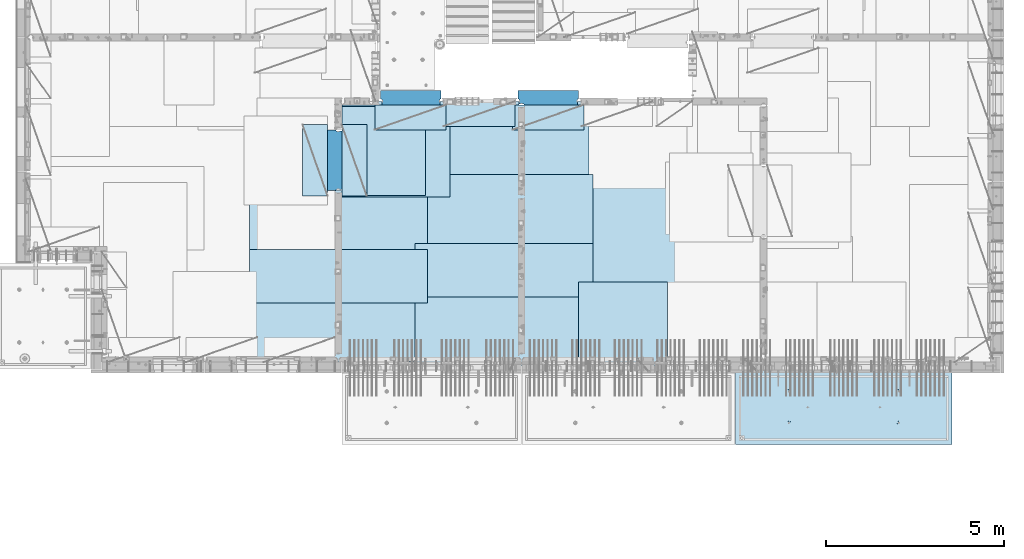
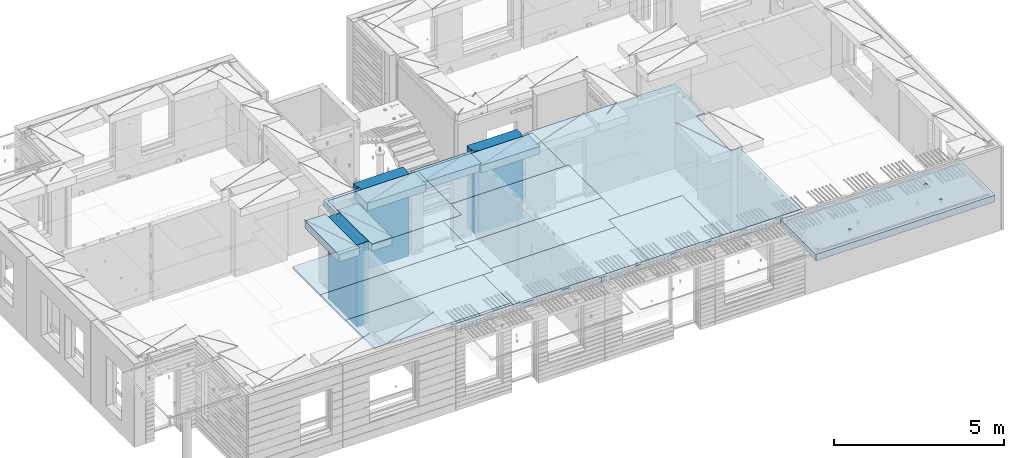
# One storey, part 196 of 334: 18 plates, 3 slabs, 19 elements without a shape of their own.
"""IFC2X3 building model written with IfcOpenShell, lengths in millimetres."""

from ifc_helpers import new_model, si_unit, frame, origin_with_axes, place, context, subcontext, project, spatial, faceted_brep, material, type_object, element, aggregate, save


model = new_model("IFC2X3")

# Units and contexts
model_context = context("Model", 3, precision=1e-05, world=origin_with_axes())
body_context = subcontext(model_context, "Body", "Model", "MODEL_VIEW")
ifc_project = project(units=[si_unit("LENGTHUNIT", "METRE", prefix="MILLI"), si_unit("AREAUNIT", "SQUARE_METRE"), si_unit("VOLUMEUNIT", "CUBIC_METRE"), si_unit("MASSUNIT", "GRAM", prefix="KILO"), si_unit("TIMEUNIT", "SECOND"), si_unit("PLANEANGLEUNIT", "RADIAN"), si_unit("SOLIDANGLEUNIT", "STERADIAN"), si_unit("THERMODYNAMICTEMPERATUREUNIT", "DEGREE_CELSIUS"), si_unit("LUMINOUSINTENSITYUNIT", "LUMEN")], contexts=[model_context])

# Site, building, storey
site_placement = place(None, origin_with_axes())
site = spatial("IfcSite", under=ifc_project, at=site_placement, CompositionType="ELEMENT")
building_placement = place(site_placement, origin_with_axes())
building = spatial("IfcBuilding", under=site, at=building_placement, CompositionType="ELEMENT")
storey_placement = place(building_placement, origin_with_axes())
storey = spatial("IfcBuildingStorey", under=building, at=storey_placement, Name="3", CompositionType="ELEMENT", Elevation=0.0)

# Assembly, slab
assembly_1_placement = place(storey_placement, origin_with_axes())
assembly_1 = element("IfcElementAssembly", 1, at=assembly_1_placement, inside=storey, AssemblyPlace="NOTDEFINED", PredefinedType="REINFORCEMENT_UNIT")
ifc_material_1 = material(Name="CONCRETE/C30/37")
slab_type_1 = type_object("IfcSlabType", PredefinedType="NOTDEFINED")
slab_1_placement = place(assembly_1_placement, frame((21810.0, 7750.0, 90595.0), z_axis=(0.0, 1.0, 0.0), x_axis=(1.0, 0.0, 0.0)))
slab_1 = element("IfcSlab", 2, at=slab_1_placement, type_object=slab_type_1, material=ifc_material_1, PredefinedType="FLOOR", context=body_context, shape_type="Brep", body=[
    faceted_brep([(6500.0, -135.0, 3780.0), (6500.0, -135.0, 3637.99963378906), (6500.0, 135.0, 3637.99963378906), (6500.0, 135.0, 3780.0), (6800.0, -135.0, 3637.99963378906), (6800.0, 135.0, 3637.99963378906), (6800.0, 135.0, 7430.0), (6800.0, -135.0, 7430.0), (6800.0, -135.0, 5680.0), (6800.0, 135.0, 5680.0), (1569.99914550782, 135.0, 7430.0), (1569.99914550782, -135.0, 7430.0), (1569.99914550782, 135.0, 7330.0), (1569.99914550782, -135.0, 7330.0), (0.0, 135.0, 7330.0), (0.0, -135.0, 7330.0), (1.81898940354586e-12, -135.0, 1.81898940354586e-12), (1.81898940354586e-12, 135.0, 1.81898940354586e-12), (6800.0, -135.0, 0.0), (6800.0, 135.0, 0.0), (6500.0, -135.0, 5637.99963378906), (6500.0, -135.0, 5680.0), (6500.0, 135.0, 5680.0), (6500.0, 135.0, 5637.99963378906)], [[[0, 1, 2, 3]], [[4, 5, 2, 1]], [[6, 7, 8, 9]], [[7, 6, 10, 11]], [[11, 10, 12, 13]], [[13, 12, 14, 15]], [[16, 15, 14, 17]], [[18, 16, 17, 19]], [[7, 11, 13, 15, 16, 18, 4, 1, 0, 20, 21, 8]], [[8, 21, 22, 9]], [[20, 0, 3, 23, 22, 21]], [[23, 3, 2, 5, 19, 17, 14, 12, 10, 6, 9, 22]], [[18, 19, 5, 4]]]),
])

assembly_2_placement = place(storey_placement, origin_with_axes())
assembly_2 = element("IfcElementAssembly", 3, at=assembly_2_placement, inside=storey, AssemblyPlace="NOTDEFINED", PredefinedType="REINFORCEMENT_UNIT")
ifc_material_2 = material(Name="CONCRETE/C35/45")
slab_type_2 = type_object("IfcSlabType", PredefinedType="NOTDEFINED")
slab_2_placement = place(assembly_2_placement, frame((33909.9998568133, 7629.99655735226, 90590.0), z_axis=(-1.11800000013248e-06, -0.999999999999375, 0.0), x_axis=(-0.999999999999093, 1.34699999998405e-06, 0.0)))
slab_2 = element("IfcSlab", 4, at=slab_2_placement, type_object=slab_type_2, material=ifc_material_2, PredefinedType="FLOOR", context=body_context, shape_type="Brep", body=[
    faceted_brep([(4605.44993885855, -113.0, 552.448239707288), (4619.38834372919, -113.0, 559.550231553701), (4630.44991833371, -113.0, 570.61183115741), (4637.55187867931, -113.0, 584.55025207851), (4639.99903540509, -113.0, 600.001104562554), (4637.55184376039, -113.0, 615.451951515985), (4630.44985191398, -113.0, 629.39035638662), (4619.38825231027, -113.0, 640.451930991143), (4605.44983138917, -113.0, 647.553891336743), (4589.99897890513, -113.0, 650.001048062522), (4574.54813195169, -113.0, 647.553856417822), (4560.60972708106, -113.0, 640.451864571409), (4549.54815247653, -113.0, 629.390264967699), (4542.44619213093, -113.0, 615.451844046599), (4539.99903540516, -113.0, 600.000991562554), (4542.44622704986, -113.0, 584.550144609124), (4549.54821889627, -113.0, 570.61173973849), (4560.60981849998, -113.0, 559.550165133966), (4574.54823942108, -113.0, 552.448204788368), (4589.99909190512, -113.0, 550.001048062586), (4548.90468317908, -120.0, 570.144182560607), (4541.68970509875, -120.0, 584.304334781456), (4560.14226277649, -120.0, 558.906628360102), (4574.30243130315, -120.0, 551.691682281732), (4589.99909280399, -120.0, 549.205593517132), (4605.69574868622, -120.0, 551.691717756181), (4619.85590090707, -120.0, 558.906695836513), (4631.09345510757, -120.0, 570.14427543392), (4638.30840118594, -120.0, 584.304443960583), (4640.79448995055, -120.0, 600.001105461418), (4638.30836571149, -120.0, 615.697761343653), (4631.09338763116, -120.0, 629.857913564502), (4619.85580803376, -120.0, 641.095467765007), (4605.6956395071, -120.0, 648.310413843377), (4589.99897800626, -120.0, 650.796502607977), (4574.30232212402, -120.0, 648.310378368928), (4560.14216990317, -120.0, 641.095400288596), (4548.90461570267, -120.0, 629.85782069119), (4541.6896696243, -120.0, 615.697652164527), (4539.2035808597, -120.0, 600.000990663691), (0.000819232023786753, -120.0, 2085.00366210938), (6090.0009765625, -120.0, 2085.00366210938), (6090.0009765625, 120.0, 2085.00366210938), (0.000819232023786753, 120.0, 2085.00366210938), (6090.0, -120.0, 1.39971234602854e-09), (6090.0, 120.0, 1.39971234602854e-09), (-7.27595761418343e-12, -120.0, -9.09494701772928e-13), (-7.27595761418343e-12, 120.0, -9.09494701772928e-13), (1515.44893888152, -108.0, 1437.45474794476), (1529.38734375216, -108.0, 1444.55673979117), (1540.44891835668, -108.0, 1455.61833939488), (1547.55087870228, -108.0, 1469.55676031598), (1549.99803542806, -108.0, 1485.00761280002), (1547.55084378336, -108.0, 1500.45845975345), (1540.44885193695, -108.0, 1514.39686462409), (1529.38725233324, -108.0, 1525.45843922861), (1515.44883141214, -108.0, 1532.56039957421), (1499.99797892809, -108.0, 1535.00755629999), (1484.54713197466, -108.0, 1532.56036465529), (1470.60872710403, -108.0, 1525.45837280888), (1459.5471524995, -108.0, 1514.39677320517), (1452.44519215391, -108.0, 1500.45835228407), (1449.99803542813, -108.0, 1485.00749980002), (1452.44522707283, -108.0, 1469.55665284659), (1459.54721891924, -108.0, 1455.61824797596), (1470.60881852295, -108.0, 1444.55667337144), (1484.54723944405, -108.0, 1437.45471302584), (1499.99809192809, -108.0, 1435.00755630005), (1451.1483322995, -120.0, 1469.13526457059), (1448.63439906449, -120.0, 1485.00749825911), (1458.44401483263, -120.0, 1454.8167213853), (1469.80729442553, -120.0, 1443.45346747338), (1484.12585409903, -120.0, 1436.15781730018), (1499.998093469, -120.0, 1433.64391993642), (1515.87032715753, -120.0, 1436.15785317143), (1530.18887034281, -120.0, 1443.45353570456), (1541.55212425473, -120.0, 1454.81681529746), (1548.84777442794, -120.0, 1469.13537497096), (1551.3616717917, -120.0, 1485.00761434093), (1548.84773855669, -120.0, 1500.87984802946), (1541.55205602355, -120.0, 1515.19839121474), (1530.18877643065, -120.0, 1526.56164512666), (1515.87021675716, -120.0, 1533.85729529987), (1499.99797738718, -120.0, 1536.37119266363), (1484.12574369866, -120.0, 1533.85725942862), (1469.80720051337, -120.0, 1526.56157689548), (1458.44394660145, -120.0, 1515.19829730258), (1451.14829642824, -120.0, 1500.87973762909), (1515.44993893152, -113.0, 552.45474794532), (1529.38834380215, -113.0, 559.556739791733), (1540.44991840668, -113.0, 570.618339395443), (1547.55187875228, -113.0, 584.556760316543), (1549.99903547806, -113.0, 600.007612800588), (1547.55184383336, -113.0, 615.458459754018), (1540.44985198694, -113.0, 629.396864624653), (1529.38825238323, -113.0, 640.458439229175), (1515.44983146213, -113.0, 647.560399574775), (1499.99897897809, -113.0, 650.007556300556), (1484.54813202466, -113.0, 647.560364655855), (1470.60972715402, -113.0, 640.458372809442), (1459.5481525495, -113.0, 629.396773205733), (1452.4461922039, -113.0, 615.458352284632), (1449.99903547812, -113.0, 600.007499800588), (1452.44622712283, -113.0, 584.556652847157), (1459.54821896923, -113.0, 570.618247976523), (1470.60981857295, -113.0, 559.556673372), (1484.54823949404, -113.0, 552.4547130264), (1499.99909197809, -113.0, 550.007556300619), (1451.68970517172, -120.0, 584.310843019489), (1449.20358093267, -120.0, 600.007498901724), (1458.90468325205, -120.0, 570.15069079864), (1470.14226284945, -120.0, 558.913136598135), (1484.30243137612, -120.0, 551.698190519764), (1499.99909287695, -120.0, 549.212101755165), (1515.69574875919, -120.0, 551.698225994213), (1529.85590098004, -120.0, 558.913204074546), (1541.09345518054, -120.0, 570.150783671952), (1548.30840125891, -120.0, 584.310952198615), (1550.79449002351, -120.0, 600.007613699451), (1548.30836578447, -120.0, 615.704269581685), (1541.09338770413, -120.0, 629.864421802535), (1529.85580810672, -120.0, 641.10197600304), (1515.69563958006, -120.0, 648.31692208141), (1499.99897807923, -120.0, 650.803010846011), (1484.30232219699, -120.0, 648.316886606961), (1470.14216997614, -120.0, 641.101908526629), (1458.90461577564, -120.0, 629.864328929222), (1451.68966969727, -120.0, 615.704160402559), (4605.44893880856, -108.0, 1437.44823970672), (4619.38734367919, -108.0, 1444.55023155314), (4630.44891828372, -108.0, 1455.61183115685), (4637.55087862931, -108.0, 1469.55025207795), (4639.99803535509, -108.0, 1485.00110456199), (4637.55084371039, -108.0, 1500.45195151542), (4630.44885186398, -108.0, 1514.39035638605), (4619.38725226027, -108.0, 1525.45193099058), (4605.44883133917, -108.0, 1532.55389133618), (4589.99797885512, -108.0, 1535.00104806196), (4574.54713190169, -108.0, 1532.55385641726), (4560.60872703106, -108.0, 1525.45186457084), (4549.54715242653, -108.0, 1514.39026496713), (4542.44519208094, -108.0, 1500.45184404603), (4539.99803535516, -108.0, 1485.00099156199), (4542.44522699986, -108.0, 1469.55014460856), (4549.54721884627, -108.0, 1455.61173973792), (4560.60881844998, -108.0, 1444.5501651334), (4574.54723937108, -108.0, 1437.4482047878), (4589.99809185513, -108.0, 1435.00104806202), (4541.14833222653, -120.0, 1469.12875633256), (4538.63439899152, -120.0, 1485.00099002108), (4548.44401475967, -120.0, 1454.81021314727), (4559.80729435257, -120.0, 1443.44695923535), (4574.12585402606, -120.0, 1436.15130906214), (4589.99809339604, -120.0, 1433.63741169839), (4605.87032708456, -120.0, 1436.1513449334), (4620.18887026985, -120.0, 1443.44702746653), (4631.55212418177, -120.0, 1454.81030705943), (4638.84777435497, -120.0, 1469.12886673293), (4641.36167171873, -120.0, 1485.0011061029), (4638.84773848372, -120.0, 1500.87333979142), (4631.55205595059, -120.0, 1515.19188297671), (4620.18877635769, -120.0, 1526.55513688863), (4605.87021668419, -120.0, 1533.85078706184), (4589.99797731422, -120.0, 1536.36468442559), (4574.12574362569, -120.0, 1533.85075119058), (4559.80720044041, -120.0, 1526.55506865745), (4548.44394652849, -120.0, 1515.19178906455), (4541.14829635528, -120.0, 1500.87322939105)], [[[0, 1, 2, 3, 4, 5, 6, 7, 8, 9, 10, 11, 12, 13, 14, 15, 16, 17, 18, 19]], [[20, 16, 15, 21]], [[22, 17, 16, 20]], [[23, 18, 17, 22]], [[24, 19, 18, 23]], [[25, 0, 19, 24]], [[26, 1, 0, 25]], [[27, 2, 1, 26]], [[28, 3, 2, 27]], [[29, 4, 3, 28]], [[30, 5, 4, 29]], [[31, 6, 5, 30]], [[32, 7, 6, 31]], [[33, 8, 7, 32]], [[34, 9, 8, 33]], [[35, 10, 9, 34]], [[36, 11, 10, 35]], [[37, 12, 11, 36]], [[38, 13, 12, 37]], [[39, 14, 13, 38]], [[21, 15, 14, 39]], [[40, 41, 42, 43]], [[41, 44, 45, 42]], [[44, 46, 47, 45]], [[42, 45, 47, 43]], [[46, 40, 43, 47]], [[48, 49, 50, 51, 52, 53, 54, 55, 56, 57, 58, 59, 60, 61, 62, 63, 64, 65, 66, 67]], [[68, 63, 62, 69]], [[70, 64, 63, 68]], [[71, 65, 64, 70]], [[72, 66, 65, 71]], [[73, 67, 66, 72]], [[74, 48, 67, 73]], [[75, 49, 48, 74]], [[76, 50, 49, 75]], [[77, 51, 50, 76]], [[78, 52, 51, 77]], [[79, 53, 52, 78]], [[80, 54, 53, 79]], [[81, 55, 54, 80]], [[82, 56, 55, 81]], [[83, 57, 56, 82]], [[84, 58, 57, 83]], [[85, 59, 58, 84]], [[86, 60, 59, 85]], [[87, 61, 60, 86]], [[69, 62, 61, 87]], [[88, 89, 90, 91, 92, 93, 94, 95, 96, 97, 98, 99, 100, 101, 102, 103, 104, 105, 106, 107]], [[108, 103, 102, 109]], [[110, 104, 103, 108]], [[111, 105, 104, 110]], [[112, 106, 105, 111]], [[113, 107, 106, 112]], [[114, 88, 107, 113]], [[115, 89, 88, 114]], [[116, 90, 89, 115]], [[117, 91, 90, 116]], [[118, 92, 91, 117]], [[119, 93, 92, 118]], [[120, 94, 93, 119]], [[121, 95, 94, 120]], [[122, 96, 95, 121]], [[123, 97, 96, 122]], [[124, 98, 97, 123]], [[125, 99, 98, 124]], [[126, 100, 99, 125]], [[127, 101, 100, 126]], [[109, 102, 101, 127]], [[128, 129, 130, 131, 132, 133, 134, 135, 136, 137, 138, 139, 140, 141, 142, 143, 144, 145, 146, 147]], [[148, 143, 142, 149]], [[150, 144, 143, 148]], [[151, 145, 144, 150]], [[152, 146, 145, 151]], [[153, 147, 146, 152]], [[154, 128, 147, 153]], [[155, 129, 128, 154]], [[156, 130, 129, 155]], [[157, 131, 130, 156]], [[158, 132, 131, 157]], [[159, 133, 132, 158]], [[160, 134, 133, 159]], [[161, 135, 134, 160]], [[162, 136, 135, 161]], [[163, 137, 136, 162]], [[164, 138, 137, 163]], [[165, 139, 138, 164]], [[166, 140, 139, 165]], [[167, 141, 140, 166]], [[149, 142, 141, 167]], [[44, 41, 40, 46], [37, 36, 35, 34, 33, 32, 31, 30, 29, 28, 27, 26, 25, 24, 23, 22, 20, 21, 39, 38], [166, 165, 164, 163, 162, 161, 160, 159, 158, 157, 156, 155, 154, 153, 152, 151, 150, 148, 149, 167], [126, 125, 124, 123, 122, 121, 120, 119, 118, 117, 116, 115, 114, 113, 112, 111, 110, 108, 109, 127], [86, 85, 84, 83, 82, 81, 80, 79, 78, 77, 76, 75, 74, 73, 72, 71, 70, 68, 69, 87]]]),
])
aggregate(assembly_2, [slab_2])

# Assembly, plate
assembly_3_placement = place(storey_placement, origin_with_axes())
assembly_3 = element("IfcElementAssembly", 5, at=assembly_3_placement, inside=storey, Name="Steel Assembly", AssemblyPlace="NOTDEFINED", PredefinedType="NOTDEFINED")
ifc_material_3 = material()
plate_type_1 = type_object("IfcPlateType", PredefinedType="NOTDEFINED")
plate_1_placement = place(assembly_3_placement, frame((25910.0, 7750.0, 90695.1), z_axis=(-1.0, 3.00000001838171e-08, 0.0), x_axis=(0.0, 1.0, 0.0)))
plate_1 = element("IfcPlate", 6, at=plate_1_placement, type_object=plate_type_1, material=ifc_material_3, Name="1/2", context=body_context, shape_type="Brep", body=[
    faceted_brep([(0.0, -35.0, 0.0), (0.0, -35.0, 2500.0), (0.0, 35.0, 2500.0), (0.0, 35.0, 0.0), (2349.99951171875, -35.0, 2500.0), (2349.99951171875, 35.0, 2500.0), (2350.0, -35.0, 0.0), (2350.0, 35.0, 0.0)], [[[0, 1, 2, 3]], [[1, 4, 5, 2]], [[4, 6, 7, 5]], [[6, 0, 3, 7]], [[5, 7, 3, 2]], [[6, 4, 1, 0]]]),
])
aggregate(assembly_3, [plate_1])

assembly_4_placement = place(storey_placement, origin_with_axes())
assembly_4 = element("IfcElementAssembly", 7, at=assembly_4_placement, inside=storey, Name="Steel Assembly", AssemblyPlace="NOTDEFINED", PredefinedType="NOTDEFINED")
plate_2_placement = place(assembly_4_placement, frame((16759.9995320312, 12530.0000289158, 90695.1), z_axis=(0.0, 1.0, 0.0), x_axis=(1.0, 0.0, 0.0)))
plate_2 = element("IfcPlate", 8, at=plate_2_placement, type_object=plate_type_1, material=ifc_material_3, Name="1/2", context=body_context, shape_type="Brep", body=[
    faceted_brep([(0.0, -35.0, 0.0), (0.0, -35.0, 2500.0), (0.0, 35.0, 2500.0), (0.0, 35.0, 0.0), (2349.99951171875, -35.0, 2500.0), (2349.99951171875, 35.0, 2500.0), (2350.0, -35.0, 0.0), (2350.0, 35.0, 0.0)], [[[0, 1, 2, 3]], [[1, 4, 5, 2]], [[4, 6, 7, 5]], [[6, 0, 3, 7]], [[5, 7, 3, 2]], [[6, 4, 1, 0]]]),
])
aggregate(assembly_4, [plate_2])

assembly_5_placement = place(storey_placement, origin_with_axes())
assembly_5 = element("IfcElementAssembly", 9, at=assembly_5_placement, inside=storey, Name="Steel Assembly", AssemblyPlace="NOTDEFINED", PredefinedType="NOTDEFINED")
plate_3_placement = place(assembly_5_placement, frame((23810.0, 10780.0, 90695.1), z_axis=(-1.0, 3.00000001838171e-08, 0.0), x_axis=(0.0, 1.0, 0.0)))
plate_3 = element("IfcPlate", 10, at=plate_3_placement, type_object=plate_type_1, material=ifc_material_3, context=body_context, shape_type="Brep", body=[
    faceted_brep([(0.0, -35.0, 0.0), (0.0, -35.0, 5000.0), (0.0, 35.0, 5000.0), (0.0, 35.0, 0.0), (2349.99951171875, -35.0, 5000.0), (2349.99951171875, 35.0, 5000.0), (2350.0, -35.0, 0.0), (2350.0, 35.0, 0.0)], [[[0, 1, 2, 3]], [[1, 4, 5, 2]], [[4, 6, 7, 5]], [[6, 0, 3, 7]], [[5, 7, 3, 2]], [[6, 4, 1, 0]]]),
])
aggregate(assembly_5, [plate_3])

assembly_6_placement = place(storey_placement, origin_with_axes())
assembly_6 = element("IfcElementAssembly", 11, at=assembly_6_placement, inside=storey, Name="Steel Assembly", AssemblyPlace="NOTDEFINED", PredefinedType="NOTDEFINED")
plate_4_placement = place(assembly_6_placement, frame((23710.0, 12730.0, 90695.1), z_axis=(-1.0, 3.00000001838171e-08, 0.0), x_axis=(0.0, 1.0, 0.0)))
plate_4 = element("IfcPlate", 12, at=plate_4_placement, type_object=plate_type_1, material=ifc_material_3, context=body_context, shape_type="Brep", body=[
    faceted_brep([(0.0, -35.0, 0.0), (0.0, -35.0, 5000.0), (0.0, 35.0, 5000.0), (0.0, 35.0, 0.0), (2349.99951171875, -35.0, 5000.0), (2349.99951171875, 35.0, 5000.0), (2350.0, -35.0, 0.0), (2350.0, 35.0, 0.0)], [[[0, 1, 2, 3]], [[1, 4, 5, 2]], [[4, 6, 7, 5]], [[6, 0, 3, 7]], [[5, 7, 3, 2]], [[6, 4, 1, 0]]]),
])
aggregate(assembly_6, [plate_4])

assembly_7_placement = place(storey_placement, origin_with_axes())
assembly_7 = element("IfcElementAssembly", 13, at=assembly_7_placement, inside=storey, Name="Steel Assembly", AssemblyPlace="NOTDEFINED", PredefinedType="NOTDEFINED")
plate_5_placement = place(assembly_7_placement, frame((23810.0, 7750.0, 90695.1), z_axis=(-1.0, 3.00000001838171e-08, 0.0), x_axis=(0.0, 1.0, 0.0)))
plate_5 = element("IfcPlate", 14, at=plate_5_placement, type_object=plate_type_1, material=ifc_material_3, context=body_context, shape_type="Brep", body=[
    faceted_brep([(0.0, -35.0, 0.0), (0.0, -35.0, 5000.0), (0.0, 35.0, 5000.0), (0.0, 35.0, 0.0), (2349.99951171875, -35.0, 5000.0), (2349.99951171875, 35.0, 5000.0), (2350.0, -35.0, 0.0), (2350.0, 35.0, 0.0)], [[[0, 1, 2, 3]], [[1, 4, 5, 2]], [[4, 6, 7, 5]], [[6, 0, 3, 7]], [[5, 7, 3, 2]], [[6, 4, 1, 0]]]),
])
aggregate(assembly_7, [plate_5])

assembly_8_placement = place(storey_placement, origin_with_axes())
assembly_8 = element("IfcElementAssembly", 15, at=assembly_8_placement, inside=storey, Name="Steel Assembly", AssemblyPlace="NOTDEFINED", PredefinedType="NOTDEFINED")
plate_6_placement = place(assembly_8_placement, frame((19160.0, 10325.0, 90695.1), z_axis=(-1.0, 3.00000001838171e-08, 0.0), x_axis=(0.0, 1.0, 0.0)))
plate_6 = element("IfcPlate", 16, at=plate_6_placement, type_object=plate_type_1, material=ifc_material_3, context=body_context, shape_type="Brep", body=[
    faceted_brep([(0.0, -35.0, 0.0), (0.0, -35.0, 5000.0), (0.0, 35.0, 5000.0), (0.0, 35.0, 0.0), (2349.99951171875, -35.0, 5000.0), (2349.99951171875, 35.0, 5000.0), (2350.0, -35.0, 0.0), (2350.0, 35.0, 0.0)], [[[0, 1, 2, 3]], [[1, 4, 5, 2]], [[4, 6, 7, 5]], [[6, 0, 3, 7]], [[5, 7, 3, 2]], [[6, 4, 1, 0]]]),
])
aggregate(assembly_8, [plate_6])

assembly_9_placement = place(storey_placement, origin_with_axes())
assembly_9 = element("IfcElementAssembly", 17, at=assembly_9_placement, inside=storey, Name="Steel Assembly", AssemblyPlace="NOTDEFINED", PredefinedType="NOTDEFINED")
plate_7_placement = place(assembly_9_placement, frame((19160.0, 7850.0, 90695.1), z_axis=(-1.0, 3.00000001838171e-08, 0.0), x_axis=(0.0, 1.0, 0.0)))
plate_7 = element("IfcPlate", 18, at=plate_7_placement, type_object=plate_type_1, material=ifc_material_3, context=body_context, shape_type="Brep", body=[
    faceted_brep([(0.0, -35.0, 0.0), (0.0, -35.0, 5000.0), (0.0, 35.0, 5000.0), (0.0, 35.0, 0.0), (2349.99951171875, -35.0, 5000.0), (2349.99951171875, 35.0, 5000.0), (2350.0, -35.0, 0.0), (2350.0, 35.0, 0.0)], [[[0, 1, 2, 3]], [[1, 4, 5, 2]], [[4, 6, 7, 5]], [[6, 0, 3, 7]], [[5, 7, 3, 2]], [[6, 4, 1, 0]]]),
])
aggregate(assembly_9, [plate_7])

assembly_10_placement = place(storey_placement, origin_with_axes())
assembly_10 = element("IfcElementAssembly", 19, at=assembly_10_placement, inside=storey, Name="Steel Assembly", AssemblyPlace="NOTDEFINED", PredefinedType="NOTDEFINED")
plate_type_2 = type_object("IfcPlateType", PredefinedType="NOTDEFINED")
plate_8_placement = place(assembly_10_placement, frame((18810.0, 11180.0000122641, 90695.1000003815), z_axis=(1.0, 0.0, 0.0), x_axis=(0.0, -1.0, 0.0)))
plate_8 = element("IfcPlate", 20, at=plate_8_placement, type_object=plate_type_2, material=ifc_material_3, context=body_context, shape_type="Brep", body=[
    faceted_brep([(0.0, -35.0, 0.0), (0.0, -35.0, 5000.0), (0.0, 35.0, 5000.0), (0.0, 35.0, 0.0), (1499.99951171875, -35.0, 5000.0), (1499.99951171875, 35.0, 5000.0), (1500.0, -35.0, 0.0), (1500.0, 35.0, 0.0)], [[[0, 1, 2, 3]], [[1, 4, 5, 2]], [[4, 6, 7, 5]], [[6, 0, 3, 7]], [[5, 7, 3, 2]], [[6, 4, 1, 0]]]),
])
aggregate(assembly_10, [plate_8])

assembly_11_placement = place(storey_placement, origin_with_axes())
assembly_11 = element("IfcElementAssembly", 21, at=assembly_11_placement, inside=storey, Name="Steel Assembly", AssemblyPlace="NOTDEFINED", PredefinedType="NOTDEFINED")
plate_9_placement = place(assembly_11_placement, frame((14160.0, 11015.0000122641, 90695.1000003815), z_axis=(1.0, 0.0, 0.0), x_axis=(0.0, -1.0, 0.0)))
plate_9 = element("IfcPlate", 22, at=plate_9_placement, type_object=plate_type_2, material=ifc_material_3, context=body_context, shape_type="Brep", body=[
    faceted_brep([(0.0, -35.0, 0.0), (0.0, -35.0, 5000.0), (0.0, 35.0, 5000.0), (0.0, 35.0, 0.0), (1499.99951171875, -35.0, 5000.0), (1499.99951171875, 35.0, 5000.0), (1500.0, -35.0, 0.0), (1500.0, 35.0, 0.0)], [[[0, 1, 2, 3]], [[1, 4, 5, 2]], [[4, 6, 7, 5]], [[6, 0, 3, 7]], [[5, 7, 3, 2]], [[6, 4, 1, 0]]]),
])
aggregate(assembly_11, [plate_9])

assembly_12_placement = place(storey_placement, origin_with_axes())
assembly_12 = element("IfcElementAssembly", 23, at=assembly_12_placement, inside=storey, Name="Steel Assembly", AssemblyPlace="NOTDEFINED", PredefinedType="NOTDEFINED")
plate_type_3 = type_object("IfcPlateType", PredefinedType="NOTDEFINED")
plate_10_placement = place(assembly_12_placement, frame((16759.9998779297, 14525.0, 90595.3), z_axis=(1.0, 0.0, 0.0), x_axis=(0.0, -1.0, 0.0)))
plate_10 = element("IfcPlate", 24, at=plate_10_placement, type_object=plate_type_3, material=ifc_material_3, Name="RE1", context=body_context, shape_type="Brep", body=[
    faceted_brep([(1.81898940354586e-12, -135.0, 1.81898940354586e-12), (0.0, -135.0, 699.999999999996), (0.0, 135.0, 699.999999999996), (1.81898940354586e-12, 135.0, 1.81898940354586e-12), (1999.99951171875, -135.0, 699.999999999993), (1999.99951171875, 135.0, 699.999999999993), (2000.0, -135.0, -3.63797880709171e-12), (2000.0, 135.0, -3.63797880709171e-12)], [[[0, 1, 2, 3]], [[1, 4, 5, 2]], [[4, 6, 7, 5]], [[6, 0, 3, 7]], [[5, 7, 3, 2]], [[6, 4, 1, 0]]]),
])
aggregate(assembly_12, [plate_10])

assembly_13_placement = place(storey_placement, origin_with_axes())
assembly_13 = element("IfcElementAssembly", 25, at=assembly_13_placement, inside=storey, Name="Steel Assembly", AssemblyPlace="NOTDEFINED", PredefinedType="NOTDEFINED")
plate_11_placement = place(assembly_13_placement, frame((16359.7701220703, 12525.0, 90595.3), z_axis=(-1.0, 3.00000001838171e-08, 0.0), x_axis=(0.0, 1.0, 0.0)))
plate_11 = element("IfcPlate", 26, at=plate_11_placement, type_object=plate_type_3, material=ifc_material_3, Name="RE1", context=body_context, shape_type="Brep", body=[
    faceted_brep([(1.81898940354586e-12, -135.0, 1.81898940354586e-12), (0.0, -135.0, 699.999999999996), (0.0, 135.0, 699.999999999996), (1.81898940354586e-12, 135.0, 1.81898940354586e-12), (1999.99951171875, -135.0, 699.999999999993), (1999.99951171875, 135.0, 699.999999999993), (2000.0, -135.0, -3.63797880709171e-12), (2000.0, 135.0, -3.63797880709171e-12)], [[[0, 1, 2, 3]], [[1, 4, 5, 2]], [[4, 6, 7, 5]], [[6, 0, 3, 7]], [[5, 7, 3, 2]], [[6, 4, 1, 0]]]),
])
aggregate(assembly_13, [plate_11])

assembly_14_placement = place(storey_placement, origin_with_axes())
assembly_14 = element("IfcElementAssembly", 27, at=assembly_14_placement, inside=storey, Name="Steel Assembly", AssemblyPlace="NOTDEFINED", PredefinedType="NOTDEFINED")
plate_12_placement = place(assembly_14_placement, frame((21624.9991457614, 15179.9998963664, 90595.3), z_axis=(0.0, -1.0, 0.0), x_axis=(-1.0, 3.00000001838171e-08, 0.0)))
plate_12 = element("IfcPlate", 28, at=plate_12_placement, type_object=plate_type_3, material=ifc_material_3, Name="RE1", context=body_context, shape_type="Brep", body=[
    faceted_brep([(1.81898940354586e-12, -135.0, 1.81898940354586e-12), (0.0, -135.0, 699.999999999996), (0.0, 135.0, 699.999999999996), (1.81898940354586e-12, 135.0, 1.81898940354586e-12), (1999.99951171875, -135.0, 699.999999999993), (1999.99951171875, 135.0, 699.999999999993), (2000.0, -135.0, -3.63797880709171e-12), (2000.0, 135.0, -3.63797880709171e-12)], [[[0, 1, 2, 3]], [[1, 4, 5, 2]], [[4, 6, 7, 5]], [[6, 0, 3, 7]], [[5, 7, 3, 2]], [[6, 4, 1, 0]]]),
])
aggregate(assembly_14, [plate_12])

assembly_15_placement = place(storey_placement, origin_with_axes())
assembly_15 = element("IfcElementAssembly", 29, at=assembly_15_placement, inside=storey, Name="Steel Assembly", AssemblyPlace="NOTDEFINED", PredefinedType="NOTDEFINED")
plate_13_placement = place(assembly_15_placement, frame((23559.9991457614, 15079.9998963664, 90595.3), z_axis=(0.0, -1.0, 0.0), x_axis=(-1.0, 3.00000001838171e-08, 0.0)))
plate_13 = element("IfcPlate", 30, at=plate_13_placement, type_object=plate_type_3, material=ifc_material_3, Name="RE1", context=body_context, shape_type="Brep", body=[
    faceted_brep([(1.81898940354586e-12, -135.0, 1.81898940354586e-12), (0.0, -135.0, 699.999999999996), (0.0, 135.0, 699.999999999996), (1.81898940354586e-12, 135.0, 1.81898940354586e-12), (1999.99951171875, -135.0, 699.999999999993), (1999.99951171875, 135.0, 699.999999999993), (2000.0, -135.0, -3.63797880709171e-12), (2000.0, 135.0, -3.63797880709171e-12)], [[[0, 1, 2, 3]], [[1, 4, 5, 2]], [[4, 6, 7, 5]], [[6, 0, 3, 7]], [[5, 7, 3, 2]], [[6, 4, 1, 0]]]),
])
aggregate(assembly_15, [plate_13])

assembly_16_placement = place(storey_placement, origin_with_axes())
assembly_16 = element("IfcElementAssembly", 31, at=assembly_16_placement, inside=storey, Name="Steel Assembly", AssemblyPlace="NOTDEFINED", PredefinedType="NOTDEFINED")
plate_14_placement = place(assembly_16_placement, frame((19689.9991457614, 15079.9998963664, 90595.3), z_axis=(0.0, -1.0, 0.0), x_axis=(-1.0, 3.00000001838171e-08, 0.0)))
plate_14 = element("IfcPlate", 32, at=plate_14_placement, type_object=plate_type_3, material=ifc_material_3, Name="RE1", context=body_context, shape_type="Brep", body=[
    faceted_brep([(1.81898940354586e-12, -135.0, 1.81898940354586e-12), (0.0, -135.0, 699.999999999996), (0.0, 135.0, 699.999999999996), (1.81898940354586e-12, 135.0, 1.81898940354586e-12), (1999.99951171875, -135.0, 699.999999999993), (1999.99951171875, 135.0, 699.999999999993), (2000.0, -135.0, -3.63797880709171e-12), (2000.0, 135.0, -3.63797880709171e-12)], [[[0, 1, 2, 3]], [[1, 4, 5, 2]], [[4, 6, 7, 5]], [[6, 0, 3, 7]], [[5, 7, 3, 2]], [[6, 4, 1, 0]]]),
])
aggregate(assembly_16, [plate_14])

# Plate
plate_type_4 = type_object("IfcPlateType", PredefinedType="NOTDEFINED")
plate_15_placement = place(assembly_1_placement, frame((16760.0002457424, 12487.9997681111, 90725.45), z_axis=(0.0, 1.0, 0.0), x_axis=(1.0, 0.0, 0.0)))
plate_15 = element("IfcPlate", 33, at=plate_15_placement, type_object=plate_type_4, material=ifc_material_3, context=body_context, shape_type="Brep", body=[
    faceted_brep([(0.0, -5.0, 0.0), (0.0, -5.0, 2592.0), (0.0, 5.0, 2592.0), (0.0, 5.0, 0.0), (3041.99975585938, -5.0, 2592.0), (3041.99975585938, 5.0, 2592.0), (3041.99975585938, -5.0, 0.0), (3041.99975585938, 5.0, 0.0)], [[[0, 1, 2, 3]], [[1, 4, 5, 2]], [[4, 6, 7, 5]], [[6, 0, 3, 7]], [[5, 7, 3, 2]], [[6, 4, 1, 0]]]),
])

# Slab
slab_type_3 = type_object("IfcSlabType", PredefinedType="NOTDEFINED")
slab_3_placement = place(assembly_1_placement, frame((21810.0, 15180.0, 90595.0), z_axis=(0.0, -1.0, 0.0), x_axis=(-1.0, 3.00000001838171e-08, 0.0)))
slab_3 = element("IfcSlab", 34, at=slab_3_placement, type_object=slab_type_3, material=ifc_material_1, PredefinedType="FLOOR", context=body_context, shape_type="Brep", body=[
    faceted_brep([(2300.00087620694, -135.0, -2.78342304227408e-06), (2300.00087620694, 135.0, 0.0), (2300.00085449219, 135.0, 100.0), (2300.00085449219, -135.0, 100.0), (3920.00085449219, 135.0, 100.0), (3920.00085449219, -135.0, 100.0), (3920.00085449219, -135.0, 0.0), (3920.00085449219, 135.0, 0.0), (5150.0, 135.0, 0.0), (5150.0, -135.0, 0.0), (5150.0, 135.0, 804.999923541527), (5150.0, -135.0, 804.999923541527), (5049.99975425761, 135.0, 804.999923541527), (5049.99975425761, -135.0, 804.999923541527), (5049.99975425761, 135.0, 2504.99992354153), (5049.99975425761, -135.0, 2504.99992354153), (5150.0, 135.0, 2504.99992354153), (5150.0, -135.0, 2504.99992354153), (5150.0, 135.0, 7330.0), (5150.0, -135.0, 7330.0), (5055.0, -135.0, 7330.0), (5055.0, 135.0, 7330.0), (5055.0, -135.0, 7430.0), (5055.0, 135.0, 7430.0), (0.0, -135.0, 7430.0), (0.0, 135.0, 7430.0), (70.0000000000036, -135.0, -8.47121555125341e-08), (3.63797880709171e-12, -135.0, 100.0), (70.0000000000036, -135.000000000015, 100.0), (70.0000000000036, 135.0, 0.0), (70.0000000000036, 135.0, 100.0), (0.0, 135.0, 100.0)], [[[0, 1, 2, 3]], [[3, 2, 4, 5]], [[6, 5, 4, 7]], [[8, 9, 6, 7]], [[9, 8, 10, 11]], [[11, 10, 12, 13]], [[13, 12, 14, 15]], [[15, 14, 16, 17]], [[18, 19, 17, 16]], [[20, 19, 18, 21]], [[22, 20, 21, 23]], [[24, 22, 23, 25]], [[26, 0, 3, 5, 6, 9, 11, 13, 15, 17, 19, 20, 22, 24, 27, 28]], [[1, 0, 26, 29]], [[25, 23, 21, 18, 16, 14, 12, 10, 8, 7, 4, 2, 1, 29, 30, 31]], [[26, 28, 30, 29]], [[27, 31, 30, 28]], [[24, 25, 31, 27]]]),
])

aggregate(assembly_1, [plate_15, slab_3, slab_1])

# Assembly, plate
assembly_17_placement = place(storey_placement, origin_with_axes())
assembly_17 = element("IfcElementAssembly", 35, at=assembly_17_placement, inside=storey, Name="Steel Assembly", AssemblyPlace="NOTDEFINED", PredefinedType="NOTDEFINED")
ifc_material_4 = material()
plate_type_5 = type_object("IfcPlateType", PredefinedType="NOTDEFINED")
plate_16_placement = place(assembly_17_placement, frame((17840.0, 15080.0, 89255.6000003815), z_axis=(0.0, 1.0, 0.0), x_axis=(1.0, 0.0, 0.0)))
plate_16 = element("IfcPlate", 36, at=plate_16_placement, type_object=plate_type_5, material=ifc_material_4, context=body_context, shape_type="Brep", body=[
    faceted_brep([(49.9991463160914, -1475.0, 156.999999814216), (49.9991455078125, -1216.89999961853, 156.999999999998), (49.9994900039455, -1216.89999961853, -0.000233727812883444), (49.9994832763732, -1475.0, 0.0), (0.0, -1475.0, 170.000000230655), (-0.00085392879191204, -1216.89999961853, 170.000000368096), (0.0, -1475.0, 400.0), (1699.99914550781, -1475.0, 400.0), (1699.99914550781, 1475.0, 400.0), (0.0, 1475.0, 400.0), (1699.99914550781, -1475.0, 169.999999999998), (1699.99914550781, 1475.0, 169.999999999998), (1669.99914550781, 1475.0, 156.999999999998), (1669.99914550781, 1475.0, 3.63797880709171e-12), (49.9994900039455, 1475.0, 0.0), (49.9991455078125, 1475.0, 156.999999999998), (0.0, 1475.0, 170.000000368096), (1669.99914550781, -1475.0, 156.999999999998), (1669.99914550781, -1475.0, 3.63797880709171e-12)], [[[0, 1, 2, 3]], [[4, 5, 1, 0]], [[6, 7, 8, 9]], [[8, 7, 10, 11]], [[9, 8, 11, 12, 13, 14, 15, 16]], [[10, 17, 12, 11]], [[18, 13, 12, 17]], [[14, 13, 18, 3, 2]], [[14, 2, 1, 15]], [[15, 1, 5, 16]], [[6, 9, 16, 5, 4]], [[18, 17, 10, 7, 6, 4, 0, 3]]]),
])
aggregate(assembly_17, [plate_16])

assembly_18_placement = place(storey_placement, origin_with_axes())
assembly_18 = element("IfcElementAssembly", 37, at=assembly_18_placement, inside=storey, Name="Steel Assembly", AssemblyPlace="NOTDEFINED", PredefinedType="NOTDEFINED")
plate_17_placement = place(assembly_18_placement, frame((21710.0, 15080.0, 89255.6000003815), z_axis=(0.0, 1.0, 0.0), x_axis=(1.0, 0.0, 0.0)))
plate_17 = element("IfcPlate", 38, at=plate_17_placement, type_object=plate_type_5, material=ifc_material_4, context=body_context, shape_type="Brep", body=[
    faceted_brep([(30.0, -1475.0, 29.9998239177003), (30.0, 1475.0, 29.9998239177003), (157.0, 1475.0, 29.9998239177003), (157.0, -1475.0, 29.9998239177003), (169.999923697669, -1475.0, 0.0), (169.999923697669, 1475.0, 0.0), (0.0, -1475.0, 170.000000230655), (0.0, 1475.0, 170.000000368096), (30.0, 1475.0, 156.999999999998), (30.0, -1475.0, 156.999999999998), (0.0, -1475.0, 400.0), (0.0, 1475.0, 400.0), (1699.99914550781, -1475.0, 400.0), (1699.99914550781, 1475.0, 400.0), (1699.99914550781, -1475.0, 169.999999999998), (1699.99914550781, 1475.0, 169.999999999998), (1669.99914550781, -1475.0, 156.999999999998), (1669.99914550781, 1475.0, 156.999999999998), (1669.99914550781, -1475.0, 3.63797880709171e-12), (1669.99914550781, 1475.0, 3.63797880709171e-12)], [[[0, 1, 2, 3]], [[4, 3, 2, 5]], [[6, 7, 8, 9]], [[10, 11, 7, 6]], [[10, 12, 13, 11]], [[13, 12, 14, 15]], [[14, 16, 17, 15]], [[18, 19, 17, 16]], [[19, 18, 4, 5]], [[1, 8, 7, 11, 13, 15, 17, 19, 5, 2]], [[9, 8, 1, 0]], [[18, 16, 14, 12, 10, 6, 9, 0, 3, 4]]]),
])
aggregate(assembly_18, [plate_17])

assembly_19_placement = place(storey_placement, origin_with_axes())
assembly_19 = element("IfcElementAssembly", 39, at=assembly_19_placement, inside=storey, Name="Steel Assembly", AssemblyPlace="NOTDEFINED", PredefinedType="NOTDEFINED")
plate_18_placement = place(assembly_19_placement, frame((16760.0, 12675.0, 89255.6000003815), z_axis=(-0.999999990476206, -0.000138013000065496, 0.0), x_axis=(-0.000138013000066464, 0.999999990476206, 0.0)))
plate_18 = element("IfcPlate", 40, at=plate_18_placement, type_object=plate_type_5, material=ifc_material_4, context=body_context, shape_type="Brep", body=[
    faceted_brep([(0.0234607562470046, -1475.0, 169.989834633274), (0.0234607562470046, 1475.0, 169.989834633274), (30.0, 1475.0, 156.999999999998), (30.0, -1475.0, 156.999999999998), (29.9999998430139, -1475.0, 0.0), (29.9999998430139, 1475.0, 0.0), (0.0552374608814716, -1475.0, 400.234619140623), (1700.05529785156, -1475.0, 399.999999999998), (1700.05529785156, 1475.0, 399.999999999998), (0.0552374608814716, 1475.0, 400.234619140623), (1700.0235408123, -1475.0, 169.775517151291), (1700.0235408123, 1475.0, 169.775517151291), (1670.00014467176, -1475.0, 156.765378823566), (1670.00014467176, 1475.0, 156.765378823566), (1670.00014467148, -1475.0, 1.13504938781261e-09), (1670.00014467148, 1475.0, 1.13504938781261e-09)], [[[0, 1, 2, 3]], [[4, 3, 2, 5]], [[6, 7, 8, 9]], [[8, 7, 10, 11]], [[12, 13, 11, 10]], [[14, 15, 13, 12]], [[15, 14, 4, 5]], [[1, 9, 8, 11, 13, 15, 5, 2]], [[6, 9, 1, 0]], [[14, 12, 10, 7, 6, 0, 3, 4]]]),
])
aggregate(assembly_19, [plate_18])

save(model, "model.ifc")
